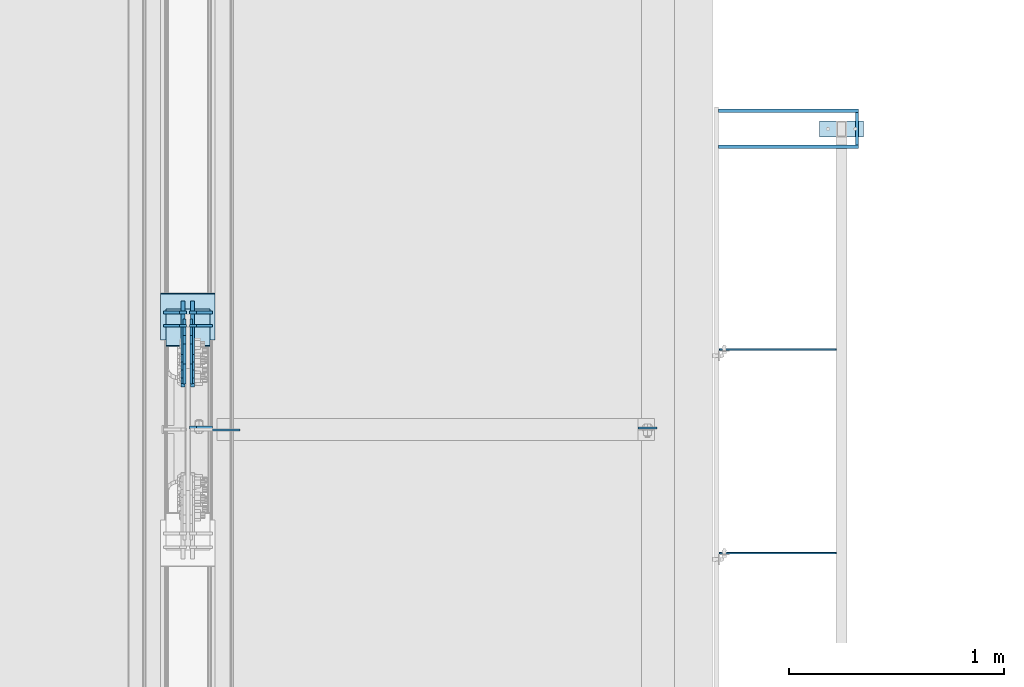
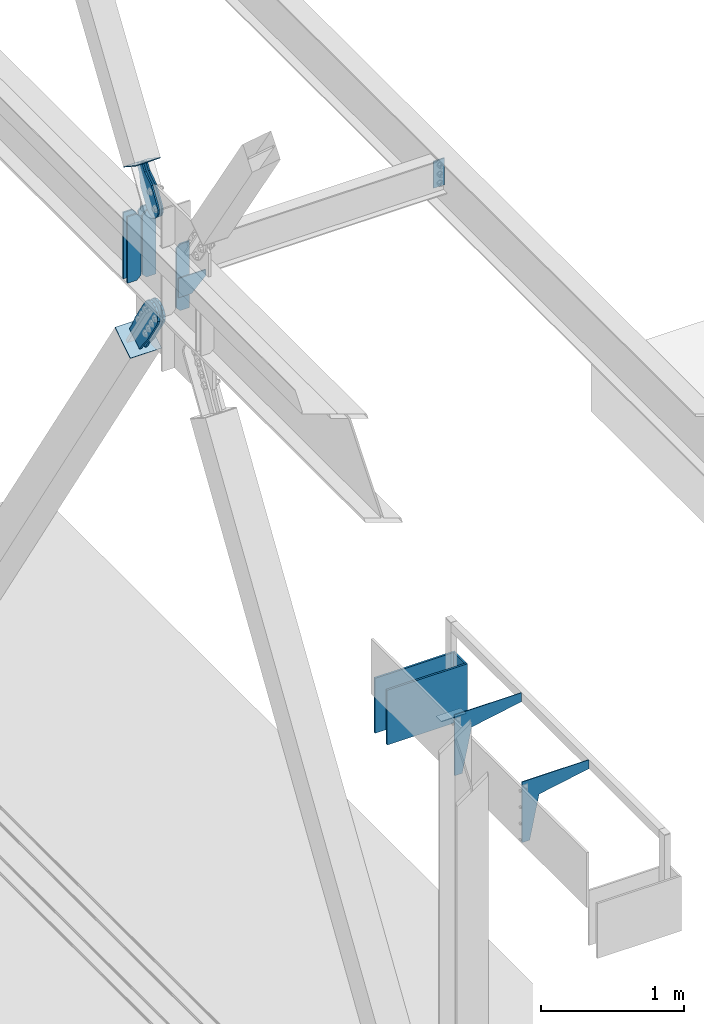
# One storey, part 3332 of 3843: 19 plates, 13 elements without a shape of their own.
"""IFC2X3 building model written with IfcOpenShell, lengths in millimetres."""

from ifc_helpers import new_model, si_unit, frame, origin_with_axes, place, context, subcontext, project, spatial, faceted_brep, material, type_object, element, aggregate, save


model = new_model("IFC2X3")

# Units and contexts
model_context = context("Model", 3, precision=1e-05, world=origin_with_axes())
body_context = subcontext(model_context, "Body", "Model", "MODEL_VIEW")
ifc_project = project(units=[si_unit("LENGTHUNIT", "METRE", prefix="MILLI"), si_unit("AREAUNIT", "SQUARE_METRE"), si_unit("VOLUMEUNIT", "CUBIC_METRE"), si_unit("MASSUNIT", "GRAM", prefix="KILO"), si_unit("TIMEUNIT", "SECOND"), si_unit("PLANEANGLEUNIT", "RADIAN"), si_unit("SOLIDANGLEUNIT", "STERADIAN"), si_unit("THERMODYNAMICTEMPERATUREUNIT", "DEGREE_CELSIUS"), si_unit("LUMINOUSINTENSITYUNIT", "LUMEN")], contexts=[model_context])

# Site, building, storey
site_placement = place(None, origin_with_axes())
site = spatial("IfcSite", under=ifc_project, at=site_placement, CompositionType="ELEMENT")
building_placement = place(site_placement, origin_with_axes())
building = spatial("IfcBuilding", under=site, at=building_placement, Name="Undefined", CompositionType="ELEMENT")
storey_placement = place(building_placement, origin_with_axes())
storey = spatial("IfcBuildingStorey", under=building, at=storey_placement, Name="Undefined", CompositionType="ELEMENT", Elevation=0.0)

# Assembly, plate
assembly_1_placement = place(storey_placement, origin_with_axes())
assembly_1 = element("IfcElementAssembly", 1, at=assembly_1_placement, inside=storey, AssemblyPlace="NOTDEFINED", PredefinedType="NOTDEFINED")
ifc_material_1 = material(Name="Drywall")
plate_type_1 = type_object("IfcPlateType", PredefinedType="NOTDEFINED")
plate_1_placement = place(assembly_1_placement, frame((3101.95308913759, 101994.44849383, 30714.95), z_axis=(0.999999999468457, -3.26049999966927e-05, 0.0), x_axis=(-3.26049999979655e-05, -0.999999999468457, 0.0)))
plate_1 = element("IfcPlate", 2, at=plate_1_placement, type_object=plate_type_1, material=ifc_material_1, context=body_context, shape_type="Brep", body=[
    faceted_brep([(3.63797880709171e-12, -234.950000000001, -1.45519152283669e-11), (-0.000517728658451233, -234.950000000001, 15.8794303852192), (-0.000517728658451233, 234.950000000001, 15.8794303852192), (3.63797880709171e-12, 234.950000000001, -1.45519152283669e-11), (152.40071802181, -234.950000000001, 15.8843994054114), (152.40071802181, 234.950000000001, 15.8843994054114), (152.401235912494, -234.950000000001, -2.11002770811319e-10), (152.401235912494, 234.950000000001, -2.11002770811319e-10)], [[[0, 1, 2, 3]], [[1, 4, 5, 2]], [[4, 6, 7, 5]], [[6, 0, 3, 7]], [[5, 7, 3, 2]], [[6, 4, 1, 0]]]),
])
aggregate(assembly_1, [plate_1])

assembly_2_placement = place(storey_placement, origin_with_axes())
assembly_2 = element("IfcElementAssembly", 3, at=assembly_2_placement, inside=storey, AssemblyPlace="NOTDEFINED", PredefinedType="NOTDEFINED")
plate_2_placement = place(assembly_2_placement, frame((2467.02025616993, 101826.196839138, 30714.95), z_axis=(7.63400000505494e-06, 0.999999999970861, 0.0), x_axis=(0.999999999970861, -7.63400000512513e-06, 0.0)))
plate_2 = element("IfcPlate", 4, at=plate_2_placement, type_object=plate_type_1, material=ifc_material_1, context=body_context, shape_type="Brep", body=[
    faceted_brep([(3.63797880709171e-12, -234.950000000001, -1.45519152283669e-11), (-7.41896983527113e-05, -234.950000000001, 15.8794303937975), (-7.41896983527113e-05, 234.950000000001, 15.8794303937975), (3.63797880709171e-12, 234.950000000001, -1.45519152283669e-11), (650.876114586341, -234.950000000001, 15.884399418268), (650.876114586341, 234.950000000001, 15.884399418268), (650.876235853531, -234.950000000001, 4.65661287307739e-09), (650.876235853531, 234.950000000001, 4.65661287307739e-09)], [[[0, 1, 2, 3]], [[1, 4, 5, 2]], [[4, 6, 7, 5]], [[6, 0, 3, 7]], [[5, 7, 3, 2]], [[6, 4, 1, 0]]]),
])
aggregate(assembly_2, [plate_2])

assembly_3_placement = place(storey_placement, origin_with_axes())
assembly_3 = element("IfcElementAssembly", 5, at=assembly_3_placement, inside=storey, AssemblyPlace="NOTDEFINED", PredefinedType="NOTDEFINED")
plate_3_placement = place(assembly_3_placement, frame((2467.02025616993, 101994.471839138, 30714.95), z_axis=(7.63400000505494e-06, 0.999999999970861, 0.0), x_axis=(0.999999999970861, -7.63400000512513e-06, 0.0)))
plate_3 = element("IfcPlate", 6, at=plate_3_placement, type_object=plate_type_1, material=ifc_material_1, context=body_context, shape_type="Brep", body=[
    faceted_brep([(3.63797880709171e-12, -234.950000000001, -1.45519152283669e-11), (-7.41896983527113e-05, -234.950000000001, 15.8794303937975), (-7.41896983527113e-05, 234.950000000001, 15.8794303937975), (3.63797880709171e-12, 234.950000000001, -1.45519152283669e-11), (650.876114586341, -234.950000000001, 15.884399418268), (650.876114586341, 234.950000000001, 15.884399418268), (650.876235853531, -234.950000000001, 4.65661287307739e-09), (650.876235853531, 234.950000000001, 4.65661287307739e-09)], [[[0, 1, 2, 3]], [[1, 4, 5, 2]], [[4, 6, 7, 5]], [[6, 0, 3, 7]], [[5, 7, 3, 2]], [[6, 4, 1, 0]]]),
])
aggregate(assembly_3, [plate_3])

# Assembly, plates
assembly_4_placement = place(storey_placement, origin_with_axes())
assembly_4 = element("IfcElementAssembly", 7, at=assembly_4_placement, inside=storey, Name="FRAME", AssemblyPlace="NOTDEFINED", PredefinedType="RIGID_FRAME")
ifc_material_2 = material(Name="STEEL/A572-50")
plate_type_2 = type_object("IfcPlateType", PredefinedType="NOTDEFINED")
plate_4_placement = place(assembly_4_placement, frame((3139.678125, 101955.6, 30483.175), z_axis=(0.0, -1.0, 0.0), x_axis=(-1.0, 0.0, 0.0)))
plate_4 = element("IfcPlate", 8, at=plate_4_placement, type_object=plate_type_2, material=ifc_material_2, Name="PLATE", context=body_context, shape_type="Brep", body=[
    faceted_brep([(0.0, -3.17499999999927, 0.0), (0.0, -3.17499999999927, 76.1999969482422), (0.0, 3.17499999999927, 76.1999969482422), (0.0, 3.17499999999927, 0.0), (203.199996948242, -3.17499999999927, 76.1999969482422), (203.199996948242, 3.17499999999927, 76.1999969482422), (203.199996948242, -3.17499999999927, 0.0), (203.199996948242, 3.17499999999927, 0.0)], [[[0, 1, 2, 3]], [[1, 4, 5, 2]], [[4, 6, 7, 5]], [[6, 0, 3, 7]], [[5, 7, 3, 2]], [[6, 4, 1, 0]]]),
])
plate_type_3 = type_object("IfcPlateType", PredefinedType="NOTDEFINED")
plate_5_placement = place(assembly_4_placement, frame((3012.678125, 100891.975001, 31305.5), z_axis=(-1.0, 0.0, 0.0), x_axis=(0.0, 0.0, -1.0)))
plate_5 = element("IfcPlate", 9, at=plate_5_placement, type_object=plate_type_3, material=ifc_material_2, Name="PLATE", context=body_context, shape_type="Brep", body=[
    faceted_brep([(0.0, -3.17499999999927, 0.0), (0.0, -3.17499999999927, 542.528124999997), (0.0, 3.17499999999927, 542.528124999997), (0.0, 3.17499999999927, 0.0), (520.700000000001, -3.17499999999927, 542.528124999997), (520.700000000001, 3.17499999999927, 542.528124999997), (520.700000000001, -3.17499999999927, 479.028124999997), (520.700000000001, 3.17499999999927, 479.028124999997), (152.400000000001, -3.17499999999927, 402.828125), (152.400000000001, 3.17499999999927, 402.828125), (76.1999999999971, -3.17499999999927, 0.0), (76.1999999999971, 3.17499999999927, 0.0)], [[[0, 1, 2, 3]], [[1, 4, 5, 2]], [[4, 6, 7, 5]], [[6, 8, 9, 7]], [[8, 10, 11, 9]], [[10, 0, 3, 11]], [[5, 7, 9, 11, 3, 2]], [[10, 8, 6, 4, 1, 0]]]),
])
plate_6_placement = place(assembly_4_placement, frame((3012.678125, 99945.825, 31305.5), z_axis=(-1.0, 0.0, 0.0), x_axis=(0.0, 0.0, -1.0)))
plate_6 = element("IfcPlate", 10, at=plate_6_placement, type_object=plate_type_3, material=ifc_material_2, Name="PLATE", context=body_context, shape_type="Brep", body=[
    faceted_brep([(0.0, -3.17499999999927, 0.0), (0.0, -3.17499999999927, 542.528124999997), (0.0, 3.17499999999927, 542.528124999997), (0.0, 3.17499999999927, 0.0), (520.700000000001, -3.17499999999927, 542.528124999997), (520.700000000001, 3.17499999999927, 542.528124999997), (520.700000000001, -3.17499999999927, 479.028124999997), (520.700000000001, 3.17499999999927, 479.028124999997), (152.400000000001, -3.17499999999927, 402.828125), (152.400000000001, 3.17499999999927, 402.828125), (76.1999999999971, -3.17499999999927, 0.0), (76.1999999999971, 3.17499999999927, 0.0)], [[[0, 1, 2, 3]], [[1, 4, 5, 2]], [[4, 6, 7, 5]], [[6, 8, 9, 7]], [[8, 10, 11, 9]], [[10, 0, 3, 11]], [[5, 7, 9, 11, 3, 2]], [[10, 8, 6, 4, 1, 0]]]),
])
aggregate(assembly_4, [plate_4, plate_5, plate_6])

# Assembly, plate
assembly_5_placement = place(storey_placement, origin_with_axes())
assembly_5 = element("IfcElementAssembly", 11, at=assembly_5_placement, inside=storey, Name="BEAM", AssemblyPlace="NOTDEFINED", PredefinedType="RIGID_FRAME")
plate_type_4 = type_object("IfcPlateType", PredefinedType="NOTDEFINED")
plate_7_placement = place(assembly_5_placement, frame((2180.43125, 100528.4375, 36398.2), z_axis=(-1.0, 0.0, 0.0), x_axis=(0.0, 0.0, -1.0)))
plate_7 = element("IfcPlate", 12, at=plate_7_placement, type_object=plate_type_4, material=ifc_material_2, Name="PLATE", context=body_context, shape_type="Brep", body=[
    faceted_brep([(0.0, -4.76249999999709, 0.0), (0.0, -4.76249999999709, 88.9000015258789), (0.0, 4.76249999999709, 88.9000015258789), (0.0, 4.76249999999709, 0.0), (228.600006102781, -4.7625000004191, 88.9000015257589), (228.600006102781, 4.76249999954598, 88.9000015257443), (228.600006103079, -4.7625000004482, 7.27595761418343e-12), (228.600006103079, 4.76249999954598, -7.27595761418343e-12)], [[[0, 1, 2, 3]], [[1, 4, 5, 2]], [[4, 6, 7, 5]], [[6, 0, 3, 7]], [[5, 7, 3, 2]], [[6, 4, 1, 0]]]),
])
aggregate(assembly_5, [plate_7])

# Assembly, plates
assembly_6_placement = place(storey_placement, origin_with_axes())
assembly_6 = element("IfcElementAssembly", 13, at=assembly_6_placement, inside=storey, Name="BEAM", AssemblyPlace="NOTDEFINED", PredefinedType="RIGID_FRAME")
plate_type_5 = type_object("IfcPlateType", PredefinedType="NOTDEFINED")
plate_8_placement = place(assembly_6_placement, frame((7.14374999999999, 100530.025000095, 35840.9875), z_axis=(0.0, 0.0, 1.0), x_axis=(1.0, 0.0, 0.0)))
plate_8 = element("IfcPlate", 14, at=plate_8_placement, type_object=plate_type_5, material=ifc_material_2, Name="PLATE", context=body_context, shape_type="Brep", body=[
    faceted_brep([(0.0, -6.35000000000582, 31.75), (-5.32907051820075e-15, -6.35000000000582, 538.162475585938), (-5.32907051820075e-15, 6.35000000000582, 538.162475585938), (0.0, 6.35000000000582, 31.75), (31.75, -6.35000000000582, 569.912475585938), (31.75, 6.35000000000582, 569.912475585938), (107.949996948242, -6.35000000000582, 569.912475585938), (107.949996948242, 6.35000000000582, 569.912475585938), (107.950000000012, -6.34999999999854, 0.0), (107.950000000012, 6.34999999999854, 0.0), (31.75, -6.35000000000582, 0.0), (31.75, 6.35000000000582, 0.0)], [[[0, 1, 2, 3]], [[1, 4, 5, 2]], [[4, 6, 7, 5]], [[6, 8, 9, 7]], [[8, 10, 11, 9]], [[10, 0, 3, 11]], [[5, 7, 9, 11, 3, 2]], [[10, 8, 6, 4, 1, 0]]]),
])
plate_type_6 = type_object("IfcPlateType", PredefinedType="NOTDEFINED")
plate_9_placement = place(assembly_6_placement, frame((-7.14375000000182, 101064.578333283, 35840.9875), z_axis=(-1.0, 0.0, 0.0), x_axis=(0.0, 0.0, 1.0)))
plate_9 = element("IfcPlate", 15, at=plate_9_placement, type_object=plate_type_6, material=ifc_material_2, Name="CB_BEAM", context=body_context, shape_type="Brep", body=[
    faceted_brep([(0.0, -6.35000000000582, 31.75), (0.0, -6.35000000000582, 107.15625), (0.0, 6.35000000000582, 107.15625), (0.0, 6.35000000000582, 31.75), (568.324999999997, -6.35000000000582, 107.15625), (568.324999999997, 6.35000000000582, 107.15625), (568.324999999997, -6.35000000000582, 31.75), (568.324999999997, 6.35000000000582, 31.75), (536.574999999997, -6.35000000000582, 0.0), (536.574999999997, 6.35000000000582, 0.0), (31.75, -6.35000000000582, 0.0), (31.75, 6.35000000000582, 0.0)], [[[0, 1, 2, 3]], [[1, 4, 5, 2]], [[4, 6, 7, 5]], [[6, 8, 9, 7]], [[8, 10, 11, 9]], [[10, 0, 3, 11]], [[5, 7, 9, 11, 3, 2]], [[10, 8, 6, 4, 1, 0]]]),
])
plate_10_placement = place(assembly_6_placement, frame((7.14374999999818, 101064.578333283, 35840.9875), z_axis=(1.0, 0.0, 0.0), x_axis=(0.0, 0.0, 1.0)))
plate_10 = element("IfcPlate", 16, at=plate_10_placement, type_object=plate_type_6, material=ifc_material_2, Name="CB_BEAM", context=body_context, shape_type="Brep", body=[
    faceted_brep([(0.0, -6.35000000000582, 31.75), (0.0, -6.35000000000582, 107.15625), (0.0, 6.35000000000582, 107.15625), (0.0, 6.35000000000582, 31.75), (568.324999999997, -6.35000000000582, 107.15625), (568.324999999997, 6.35000000000582, 107.15625), (568.324999999997, -6.35000000000582, 31.75), (568.324999999997, 6.35000000000582, 31.75), (536.574999999997, -6.35000000000582, 0.0), (536.574999999997, 6.35000000000582, 0.0), (31.75, -6.35000000000582, 0.0), (31.75, 6.35000000000582, 0.0)], [[[0, 1, 2, 3]], [[1, 4, 5, 2]], [[4, 6, 7, 5]], [[6, 8, 9, 7]], [[8, 10, 11, 9]], [[10, 0, 3, 11]], [[5, 7, 9, 11, 3, 2]], [[10, 8, 6, 4, 1, 0]]]),
])
plate_11_placement = place(assembly_6_placement, frame((-7.14375000000182, 101003.425652439, 35840.9875), z_axis=(-1.0, 0.0, 0.0), x_axis=(0.0, 0.0, 1.0)))
plate_11 = element("IfcPlate", 17, at=plate_11_placement, type_object=plate_type_6, material=ifc_material_2, Name="CB_BEAM", context=body_context, shape_type="Brep", body=[
    faceted_brep([(0.0, -6.35000000000582, 31.75), (0.0, -6.35000000000582, 107.15625), (0.0, 6.35000000000582, 107.15625), (0.0, 6.35000000000582, 31.75), (568.324999999997, -6.35000000000582, 107.15625), (568.324999999997, 6.35000000000582, 107.15625), (568.324999999997, -6.35000000000582, 31.75), (568.324999999997, 6.35000000000582, 31.75), (536.574999999997, -6.35000000000582, 0.0), (536.574999999997, 6.35000000000582, 0.0), (31.75, -6.35000000000582, 0.0), (31.75, 6.35000000000582, 0.0)], [[[0, 1, 2, 3]], [[1, 4, 5, 2]], [[4, 6, 7, 5]], [[6, 8, 9, 7]], [[8, 10, 11, 9]], [[10, 0, 3, 11]], [[5, 7, 9, 11, 3, 2]], [[10, 8, 6, 4, 1, 0]]]),
])
plate_12_placement = place(assembly_6_placement, frame((7.14374999999818, 101003.425652439, 35840.9875), z_axis=(1.0, 0.0, 0.0), x_axis=(0.0, 0.0, 1.0)))
plate_12 = element("IfcPlate", 18, at=plate_12_placement, type_object=plate_type_6, material=ifc_material_2, Name="CB_BEAM", context=body_context, shape_type="Brep", body=[
    faceted_brep([(0.0, -6.35000000000582, 31.75), (0.0, -6.35000000000582, 107.15625), (0.0, 6.35000000000582, 107.15625), (0.0, 6.35000000000582, 31.75), (568.324999999997, -6.35000000000582, 107.15625), (568.324999999997, 6.35000000000582, 107.15625), (568.324999999997, -6.35000000000582, 31.75), (568.324999999997, 6.35000000000582, 31.75), (536.574999999997, -6.35000000000582, 0.0), (536.574999999997, 6.35000000000582, 0.0), (31.75, -6.35000000000582, 0.0), (31.75, 6.35000000000582, 0.0)], [[[0, 1, 2, 3]], [[1, 4, 5, 2]], [[4, 6, 7, 5]], [[6, 8, 9, 7]], [[8, 10, 11, 9]], [[10, 0, 3, 11]], [[5, 7, 9, 11, 3, 2]], [[10, 8, 6, 4, 1, 0]]]),
])
aggregate(assembly_6, [plate_9, plate_10, plate_11, plate_12, plate_8])

# Assembly, plate
assembly_7_placement = place(storey_placement, origin_with_axes())
assembly_7 = element("IfcElementAssembly", 19, at=assembly_7_placement, inside=storey, AssemblyPlace="NOTDEFINED", PredefinedType="RIGID_FRAME")
ifc_material_3 = material(Name="STEEL/A36")
plate_type_7 = type_object("IfcPlateType", PredefinedType="NOTDEFINED")
plate_13_placement = place(assembly_7_placement, frame((-15.875, 100994.626658627, 36759.4293704214), z_axis=(0.0, -0.834244522688862, 0.551394664794313), x_axis=(0.0, 0.551394664794348, 0.834244522688839)))
plate_13 = element("IfcPlate", 20, at=plate_13_placement, type_object=plate_type_7, material=ifc_material_3, context=body_context, shape_type="Brep", body=[
    faceted_brep([(0.0, -6.3499999046162, 0.0), (-101.599999999482, -6.35000000000582, -44.6881937832222), (-101.599999999482, 6.35000000000582, -44.6881937832222), (7.27595761418343e-12, 6.3499999046162, 0.0), (-246.684985846376, -6.35000000000582, -44.6881937832586), (-246.684985846376, 6.35000000000582, -44.6881937832586), (-281.313054100305, -6.35000000000582, -37.8002427490646), (-281.313054100305, 6.35000000000582, -37.8002427490646), (-310.669312866783, -6.35000000000582, -18.18501775197), (-310.669312866783, 6.35000000000582, -18.18501775197), (-330.284537863758, -6.35000000000582, 11.1712410146756), (-330.284537863758, 6.35000000000582, 11.1712410146756), (-337.172488897893, -6.35000000000582, 45.7993031645856), (-337.172488897893, 6.35000000000582, 45.7993031645856), (-330.284537863699, -6.35000000000582, 80.4273714186893), (-330.284537863699, 6.35000000000582, 80.4273714186893), (-310.669312866681, -6.35000000000582, 109.783630185331), (-310.669312866681, 6.35000000000582, 109.783630185331), (-281.313054100174, -6.35000000000582, 129.39885518244), (-281.313054100174, 6.35000000000582, 129.39885518244), (-246.684988898312, -6.35000000000582, 136.286806216667), (-246.684988898312, 6.35000000000582, 136.286806216667), (-101.599999999322, -6.35000000000582, 136.286806216689), (-101.599999999322, 6.35000000000582, 136.286806216689), (2.18278728425503e-10, -6.35000000000582, 91.5986124321353), (2.18278728425503e-10, 6.35000000000582, 91.5986124321353), (69.8499999987471, -6.35000000000582, 91.598612432037), (69.8499999987471, 6.35000000000582, 91.598612432037), (69.8499999985434, -6.35000000000582, -8.73114913702011e-11), (69.8499999985434, 6.35000000000582, -8.73114913702011e-11)], [[[0, 1, 2, 3]], [[1, 4, 5, 2]], [[4, 6, 7, 5]], [[6, 8, 9, 7]], [[8, 10, 11, 9]], [[10, 12, 13, 11]], [[12, 14, 15, 13]], [[14, 16, 17, 15]], [[16, 18, 19, 17]], [[18, 20, 21, 19]], [[20, 22, 23, 21]], [[22, 24, 25, 23]], [[24, 26, 27, 25]], [[26, 28, 29, 27]], [[28, 0, 3, 29]], [[5, 7, 9, 11, 13, 15, 17, 19, 21, 23, 25, 27, 29, 3, 2]], [[28, 26, 24, 22, 20, 18, 16, 14, 12, 10, 8, 6, 4, 1, 0]]]),
])
aggregate(assembly_7, [plate_13])

assembly_8_placement = place(storey_placement, origin_with_axes())
assembly_8 = element("IfcElementAssembly", 21, at=assembly_8_placement, inside=storey, AssemblyPlace="NOTDEFINED", PredefinedType="RIGID_FRAME")
plate_14_placement = place(assembly_8_placement, frame((15.875, 100994.626658627, 36759.4293704214), z_axis=(0.0, -0.834244522688862, 0.551394664794313), x_axis=(0.0, 0.551394664794348, 0.834244522688839)))
plate_14 = element("IfcPlate", 22, at=plate_14_placement, type_object=plate_type_7, material=ifc_material_3, context=body_context, shape_type="Brep", body=[
    faceted_brep([(0.0, -6.3499999046162, 0.0), (-101.599999999482, -6.35000000000582, -44.6881937832222), (-101.599999999482, 6.35000000000582, -44.6881937832222), (7.27595761418343e-12, 6.3499999046162, 0.0), (-246.684985846376, -6.35000000000582, -44.6881937832586), (-246.684985846376, 6.35000000000582, -44.6881937832586), (-281.313054100305, -6.35000000000582, -37.8002427490646), (-281.313054100305, 6.35000000000582, -37.8002427490646), (-310.669312866783, -6.35000000000582, -18.18501775197), (-310.669312866783, 6.35000000000582, -18.18501775197), (-330.284537863758, -6.35000000000582, 11.1712410146756), (-330.284537863758, 6.35000000000582, 11.1712410146756), (-337.172488897893, -6.35000000000582, 45.7993031645856), (-337.172488897893, 6.35000000000582, 45.7993031645856), (-330.284537863699, -6.35000000000582, 80.4273714186893), (-330.284537863699, 6.35000000000582, 80.4273714186893), (-310.669312866681, -6.35000000000582, 109.783630185331), (-310.669312866681, 6.35000000000582, 109.783630185331), (-281.313054100174, -6.35000000000582, 129.39885518244), (-281.313054100174, 6.35000000000582, 129.39885518244), (-246.684988898312, -6.35000000000582, 136.286806216667), (-246.684988898312, 6.35000000000582, 136.286806216667), (-101.599999999322, -6.35000000000582, 136.286806216689), (-101.599999999322, 6.35000000000582, 136.286806216689), (2.18278728425503e-10, -6.35000000000582, 91.5986124321353), (2.18278728425503e-10, 6.35000000000582, 91.5986124321353), (69.8499999987471, -6.35000000000582, 91.598612432037), (69.8499999987471, 6.35000000000582, 91.598612432037), (69.8499999985434, -6.35000000000582, -8.73114913702011e-11), (69.8499999985434, 6.35000000000582, -8.73114913702011e-11)], [[[0, 1, 2, 3]], [[1, 4, 5, 2]], [[4, 6, 7, 5]], [[6, 8, 9, 7]], [[8, 10, 11, 9]], [[10, 12, 13, 11]], [[12, 14, 15, 13]], [[14, 16, 17, 15]], [[16, 18, 19, 17]], [[18, 20, 21, 19]], [[20, 22, 23, 21]], [[22, 24, 25, 23]], [[24, 26, 27, 25]], [[26, 28, 29, 27]], [[28, 0, 3, 29]], [[5, 7, 9, 11, 13, 15, 17, 19, 21, 23, 25, 27, 29, 3, 2]], [[28, 26, 24, 22, 20, 18, 16, 14, 12, 10, 8, 6, 4, 1, 0]]]),
])
aggregate(assembly_8, [plate_14])

assembly_9_placement = place(storey_placement, origin_with_axes())
assembly_9 = element("IfcElementAssembly", 23, at=assembly_9_placement, inside=storey, Name="Plate", AssemblyPlace="NOTDEFINED", PredefinedType="RIGID_FRAME")
plate_type_8 = type_object("IfcPlateType", PredefinedType="NOTDEFINED")
plate_15_placement = place(assembly_9_placement, frame((101.6, 101077.942321066, 36784.2844191222), z_axis=(0.0, -0.834244522688862, 0.551394664794313), x_axis=(-1.0, 0.0, 0.0)))
plate_15 = element("IfcPlate", 24, at=plate_15_placement, type_object=plate_type_8, material=ifc_material_3, Name="Plate", context=body_context, shape_type="Brep", body=[
    faceted_brep([(0.0, -3.17499999999927, 0.0), (0.0, -3.17500000043947, 203.200000001736), (0.0, 3.1749999995518, 203.200000001743), (0.0, 3.17499999999927, 0.0), (203.200000000012, -3.17500000043947, 203.200000001736), (203.200000000012, 3.1749999995518, 203.200000001743), (203.199996948242, -3.17499999999927, 0.0), (203.199996948242, 3.17499999999927, 0.0)], [[[0, 1, 2, 3]], [[1, 4, 5, 2]], [[4, 6, 7, 5]], [[6, 0, 3, 7]], [[5, 7, 3, 2]], [[6, 4, 1, 0]]]),
])
aggregate(assembly_9, [plate_15])

assembly_10_placement = place(storey_placement, origin_with_axes())
assembly_10 = element("IfcElementAssembly", 25, at=assembly_10_placement, inside=storey, Name="BEAM", AssemblyPlace="NOTDEFINED", PredefinedType="RIGID_FRAME")
plate_type_9 = type_object("IfcPlateType", PredefinedType="NOTDEFINED")
plate_16_placement = place(assembly_10_placement, frame((241.300003051758, 100518.912999916, 36128.325), z_axis=(0.0, 0.0, -1.0), x_axis=(-1.0, 0.0, 0.0)))
plate_16 = element("IfcPlate", 26, at=plate_16_placement, type_object=plate_type_9, material=ifc_material_2, Name="PLATE", context=body_context, shape_type="Brep", body=[
    faceted_brep([(0.0, -4.76249999999709, 0.0), (0.0, -4.76249999999709, 50.7999999999993), (0.0, 4.76249999999709, 50.7999999999993), (0.0, 4.76249999999709, 0.0), (114.300003051758, -4.76249999999709, 165.100006103516), (114.300003051758, 4.76249999999709, 165.100006103516), (221.456237792969, -4.76249999999709, 165.100006103516), (221.456237792969, 4.76249999999709, 165.100006103516), (221.456237792969, -4.76249999999709, 0.0), (221.456237792969, 4.76249999999709, 0.0)], [[[0, 1, 2, 3]], [[1, 4, 5, 2]], [[4, 6, 7, 5]], [[6, 8, 9, 7]], [[8, 0, 3, 9]], [[5, 7, 9, 3, 2]], [[8, 6, 4, 1, 0]]]),
])
aggregate(assembly_10, [plate_16])

assembly_11_placement = place(storey_placement, origin_with_axes())
assembly_11 = element("IfcElementAssembly", 27, at=assembly_11_placement, inside=storey, AssemblyPlace="NOTDEFINED", PredefinedType="RIGID_FRAME")
plate_type_10 = type_object("IfcPlateType", PredefinedType="NOTDEFINED")
plate_17_placement = place(assembly_11_placement, frame((22.225, 100939.015202357, 35315.7899046132), z_axis=(0.0, 0.841839592004238, 0.539727803002715), x_axis=(0.0, 0.53972780300272, -0.841839592004235)))
plate_17 = element("IfcPlate", 28, at=plate_17_placement, type_object=plate_type_10, material=ifc_material_3, context=body_context, shape_type="Brep", body=[
    faceted_brep([(0.0, -9.52500000000146, 0.0), (-101.599999999351, -9.52499999999418, -12.3260213857429), (-101.599999999351, 9.52499999999418, -12.3260213857429), (0.0, 9.52500000000146, 0.0), (-364.729297663791, -9.52499999999418, -12.3260213864851), (-364.729297663791, 9.52499999999418, -12.3260213864851), (-401.787405129209, -9.52499999999418, -4.95470550008758), (-401.787405129209, 9.52499999999418, -4.95470550008758), (-433.203751665707, -9.52499999999418, 16.0370261367789), (-433.203751665707, 9.52499999999418, 16.0370261367789), (-454.195483303061, -9.52499999999418, 47.4533726729569), (-454.195483303061, 9.52499999999418, 47.4533726729569), (-461.566799190045, -9.52499999999418, 84.5114770857908), (-461.566799190045, 9.52499999999418, 84.5114770857908), (-454.195483303822, -9.52499999999418, 121.569584551733), (-454.195483303822, 9.52499999999418, 121.569584551733), (-433.203751666773, -9.52499999999418, 152.985931088682), (-433.203751666773, 9.52499999999418, 152.985931088682), (-401.787405130151, -9.52499999999418, 173.977662726218), (-401.787405130151, 9.52499999999418, 173.977662726218), (-364.729299191746, -9.52499999999418, 181.348978613009), (-364.729299191746, 9.52499999999418, 181.348978613009), (-101.600000001839, -9.52499999999418, 181.348978613736), (-101.600000001839, 9.52499999999418, 181.348978613736), (-2.16823536902666e-09, -9.52499999999418, 169.022957228546), (-2.16823536902666e-09, 9.52499999999418, 169.022957228546), (69.8499999974956, -9.52499999999418, 169.02295722875), (69.8499999974956, 9.52499999999418, 169.02295722875), (69.8499999979995, -9.52499999999418, -4.00177668780088e-10), (69.8499999979995, 9.52499999999418, -4.00177668780088e-10)], [[[0, 1, 2, 3]], [[1, 4, 5, 2]], [[4, 6, 7, 5]], [[6, 8, 9, 7]], [[8, 10, 11, 9]], [[10, 12, 13, 11]], [[12, 14, 15, 13]], [[14, 16, 17, 15]], [[16, 18, 19, 17]], [[18, 20, 21, 19]], [[20, 22, 23, 21]], [[22, 24, 25, 23]], [[24, 26, 27, 25]], [[26, 28, 29, 27]], [[28, 0, 3, 29]], [[5, 7, 9, 11, 13, 15, 17, 19, 21, 23, 25, 27, 29, 3, 2]], [[28, 26, 24, 22, 20, 18, 16, 14, 12, 10, 8, 6, 4, 1, 0]]]),
])
aggregate(assembly_11, [plate_17])

assembly_12_placement = place(storey_placement, origin_with_axes())
assembly_12 = element("IfcElementAssembly", 29, at=assembly_12_placement, inside=storey, AssemblyPlace="NOTDEFINED", PredefinedType="RIGID_FRAME")
plate_18_placement = place(assembly_12_placement, frame((-22.225, 100939.015202357, 35315.7899046132), z_axis=(0.0, 0.841839592004238, 0.539727803002715), x_axis=(0.0, 0.53972780300272, -0.841839592004235)))
plate_18 = element("IfcPlate", 30, at=plate_18_placement, type_object=plate_type_10, material=ifc_material_3, context=body_context, shape_type="Brep", body=[
    faceted_brep([(0.0, -9.52500000000146, 0.0), (-101.599999999351, -9.52499999999418, -12.3260213857429), (-101.599999999351, 9.52499999999418, -12.3260213857429), (0.0, 9.52500000000146, 0.0), (-364.729297663791, -9.52499999999418, -12.3260213864851), (-364.729297663791, 9.52499999999418, -12.3260213864851), (-401.787405129209, -9.52499999999418, -4.95470550008758), (-401.787405129209, 9.52499999999418, -4.95470550008758), (-433.203751665707, -9.52499999999418, 16.0370261367789), (-433.203751665707, 9.52499999999418, 16.0370261367789), (-454.195483303061, -9.52499999999418, 47.4533726729569), (-454.195483303061, 9.52499999999418, 47.4533726729569), (-461.566799190045, -9.52499999999418, 84.5114770857908), (-461.566799190045, 9.52499999999418, 84.5114770857908), (-454.195483303822, -9.52499999999418, 121.569584551733), (-454.195483303822, 9.52499999999418, 121.569584551733), (-433.203751666773, -9.52499999999418, 152.985931088682), (-433.203751666773, 9.52499999999418, 152.985931088682), (-401.787405130151, -9.52499999999418, 173.977662726218), (-401.787405130151, 9.52499999999418, 173.977662726218), (-364.729299191746, -9.52499999999418, 181.348978613009), (-364.729299191746, 9.52499999999418, 181.348978613009), (-101.600000001839, -9.52499999999418, 181.348978613736), (-101.600000001839, 9.52499999999418, 181.348978613736), (-2.16823536902666e-09, -9.52499999999418, 169.022957228546), (-2.16823536902666e-09, 9.52499999999418, 169.022957228546), (69.8499999974956, -9.52499999999418, 169.02295722875), (69.8499999974956, 9.52499999999418, 169.02295722875), (69.8499999979995, -9.52499999999418, -4.00177668780088e-10), (69.8499999979995, 9.52499999999418, -4.00177668780088e-10)], [[[0, 1, 2, 3]], [[1, 4, 5, 2]], [[4, 6, 7, 5]], [[6, 8, 9, 7]], [[8, 10, 11, 9]], [[10, 12, 13, 11]], [[12, 14, 15, 13]], [[14, 16, 17, 15]], [[16, 18, 19, 17]], [[18, 20, 21, 19]], [[20, 22, 23, 21]], [[22, 24, 25, 23]], [[24, 26, 27, 25]], [[26, 28, 29, 27]], [[28, 0, 3, 29]], [[5, 7, 9, 11, 13, 15, 17, 19, 21, 23, 25, 27, 29, 3, 2]], [[28, 26, 24, 22, 20, 18, 16, 14, 12, 10, 8, 6, 4, 1, 0]]]),
])
aggregate(assembly_12, [plate_18])

assembly_13_placement = place(storey_placement, origin_with_axes())
assembly_13 = element("IfcElementAssembly", 31, at=assembly_13_placement, inside=storey, Name="Plate", AssemblyPlace="NOTDEFINED", PredefinedType="RIGID_FRAME")
plate_type_11 = type_object("IfcPlateType", PredefinedType="NOTDEFINED")
plate_19_placement = place(assembly_13_placement, frame((127.0, 101153.060290653, 35373.8188755934), z_axis=(0.0, -0.841839592004235, -0.53972780300272), x_axis=(-1.0, 0.0, 0.0)))
plate_19 = element("IfcPlate", 32, at=plate_19_placement, type_object=plate_type_11, material=ifc_material_3, Name="Plate", context=body_context, shape_type="Brep", body=[
    faceted_brep([(0.0, -3.17499999999927, 0.0), (0.0, -3.17499999965185, 254.000000005151), (0.0, 3.17500000035216, 254.000000005166), (0.0, 3.17499999999927, 0.0), (254.0, -3.17499999965185, 254.000000005151), (254.0, 3.17500000035216, 254.000000005166), (254.0, -3.17500000000291, 0.0), (254.0, 3.17499999999927, 1.45519152283669e-11)], [[[0, 1, 2, 3]], [[1, 4, 5, 2]], [[4, 6, 7, 5]], [[6, 0, 3, 7]], [[5, 7, 3, 2]], [[6, 4, 1, 0]]]),
])
aggregate(assembly_13, [plate_19])

save(model, "model.ifc")
